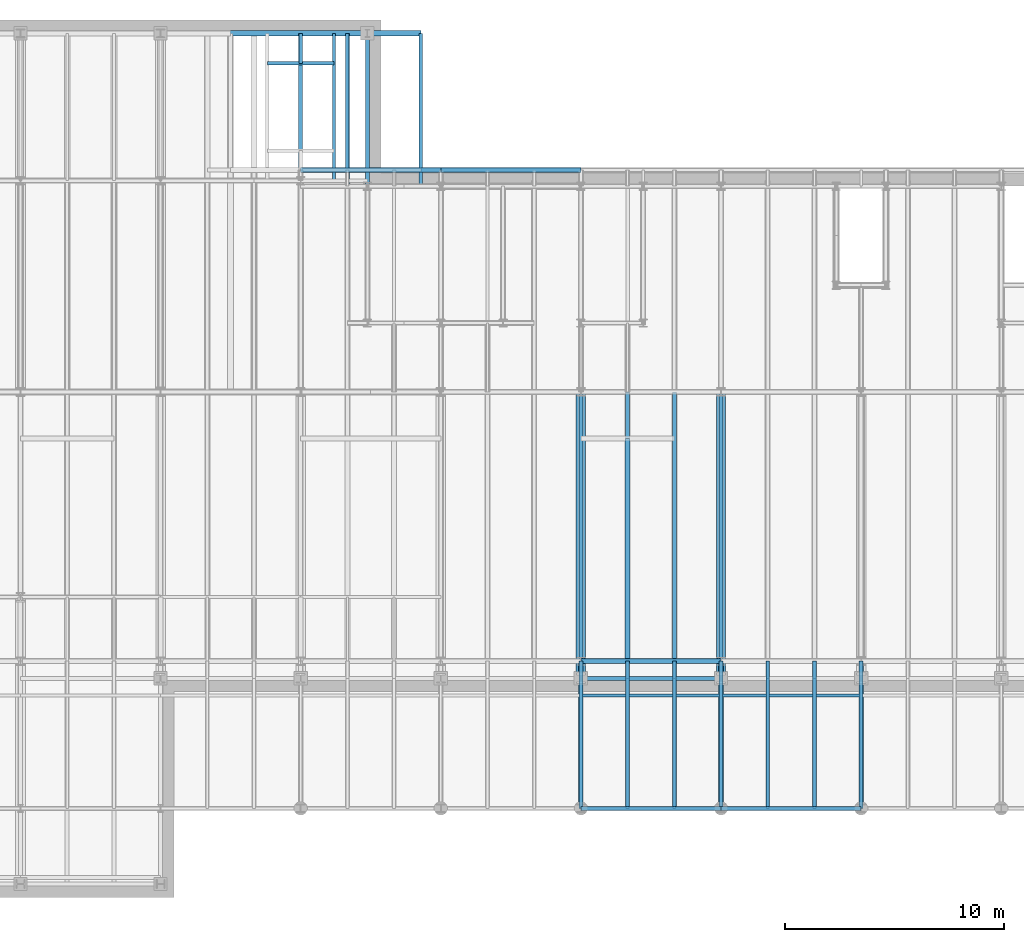
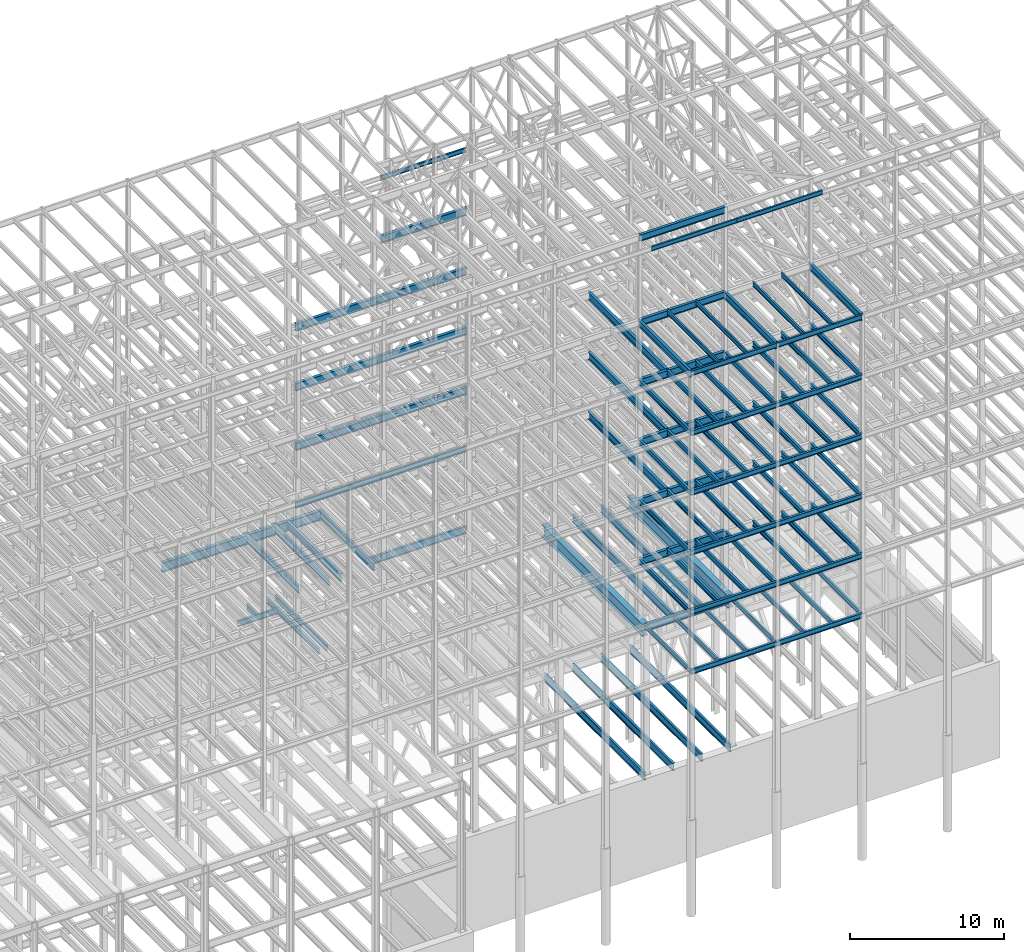
# One storey, part 138 of 150: 95 beams.
"""IFC2X3 building model written with IfcOpenShell, lengths in millimetres."""

import ifcopenshell
import ifcopenshell.guid

model = None  # the IFC model being written
_history = None  # IfcOwnerHistory: only IFC2X3 demands one
_inside = {}  # id of a spatial element -> (the spatial element, [elements in it])
_under = {}  # id of a project, library or spatial element -> (it, [spatial elements below it])
_declared = {}  # id of a project -> (the project, [libraries it declares])
_typed = {}  # id of a type object -> (the type object, [elements of that type])
_made_of = {}  # id of a material, layer set ... -> (it, [elements and type objects made of it])


def new_model(schema):
    """Start an empty IFC model of exactly this schema.

    Asked for "IFC4X3", IfcOpenShell would pick the latest addendum, in which some entities
    have other attributes; the version numbers below select the first issue.
    IFC2X3 requires an IfcOwnerHistory on every rooted entity: one is made here for all.
    """
    global model, _history
    if schema == "IFC4X3":
        model = ifcopenshell.file(schema_version=(4, 3, 0, 0))
    else:
        model = ifcopenshell.file(schema=schema)
    _inside.clear()
    _under.clear()
    _declared.clear()
    _typed.clear()
    _made_of.clear()
    _history = None
    if model.schema == "IFC2X3":
        org = make("IfcOrganization", Name="unknown")
        user = make(
            "IfcPersonAndOrganization",
            ThePerson=make("IfcPerson", FamilyName="unknown"),
            TheOrganization=org,
        )
        app = make(
            "IfcApplication",
            ApplicationDeveloper=org,
            Version="unknown",
            ApplicationFullName="unknown",
            ApplicationIdentifier="unknown",
        )
        _history = make(
            "IfcOwnerHistory",
            OwningUser=user,
            OwningApplication=app,
            ChangeAction="ADDED",
            CreationDate=0,
        )
    return model


def make(cls, **values):
    """One entity of the class cls with the attributes given. An attribute that is None is left unset."""
    return model.create_entity(
        cls, **{name: value for name, value in values.items() if value is not None}
    )


def rooted(cls, **values):
    """An entity with a GlobalId (a new one), such as an element, a storey or a relation."""
    return make(cls, GlobalId=ifcopenshell.guid.new(), OwnerHistory=_history, **values)


def si_unit(unit_type, name, prefix=None):
    """IfcSIUnit, for example si_unit("LENGTHUNIT", "METRE", prefix="MILLI")."""
    return make("IfcSIUnit", UnitType=unit_type, Prefix=prefix, Name=name)


def assignment(units):
    """IfcUnitAssignment: the units of a project."""
    return None if units is None else make("IfcUnitAssignment", Units=units)


def point(xyz):
    """IfcCartesianPoint."""
    return None if xyz is None else make("IfcCartesianPoint", Coordinates=xyz)


def direction(xyz):
    """IfcDirection."""
    return None if xyz is None else make("IfcDirection", DirectionRatios=xyz)


def frame(location, z_axis=None, x_axis=None):
    """IfcAxis2Placement3D, a coordinate frame: its origin and axes. An axis left out is left unset."""
    return make(
        "IfcAxis2Placement3D",
        Location=point(location),
        Axis=direction(z_axis),
        RefDirection=direction(x_axis),
    )


def frame_2d(location, x_axis=None):
    """IfcAxis2Placement2D, a coordinate frame in the plane: its origin and x axis."""
    return make(
        "IfcAxis2Placement2D", Location=point(location), RefDirection=direction(x_axis)
    )


def origin_with_axes():
    """The frame at (0, 0, 0) with the z axis (0, 0, 1) and the x axis (1, 0, 0) written out."""
    return frame((0.0, 0.0, 0.0), z_axis=(0.0, 0.0, 1.0), x_axis=(1.0, 0.0, 0.0))


def origin_2d_with_axis():
    """The frame at (0, 0) in the plane with the x axis (1, 0) written out."""
    return frame_2d((0.0, 0.0), x_axis=(1.0, 0.0))


def place(relative_to, where):
    """IfcLocalPlacement: puts the frame where relative to a parent placement (None: the world)."""
    return make(
        "IfcLocalPlacement", PlacementRelTo=relative_to, RelativePlacement=where
    )


def context(
    kind, dimensions, precision=None, world=None, true_north=None, identifier=None
):
    """IfcGeometricRepresentationContext, for example the 3D "Model" context."""
    return make(
        "IfcGeometricRepresentationContext",
        ContextIdentifier=identifier,
        ContextType=kind,
        CoordinateSpaceDimension=dimensions,
        Precision=precision,
        WorldCoordinateSystem=world,
        TrueNorth=true_north,
    )


def subcontext(parent, identifier, kind, view, scale=None):
    """IfcGeometricRepresentationSubContext, for example "Body" below "Model"."""
    return make(
        "IfcGeometricRepresentationSubContext",
        ContextIdentifier=identifier,
        ContextType=kind,
        ParentContext=parent,
        TargetScale=scale,
        TargetView=view,
    )


def project(units=None, contexts=None):
    """IfcProject with its units and contexts."""
    return rooted(
        "IfcProject",
        Name="project",
        RepresentationContexts=contexts,
        UnitsInContext=assignment(units),
    )


def spatial(cls, under=None, at=None, **own):
    """A site, building, storey or space (cls), placed at a placement, below another one or the project."""
    s = rooted(cls, ObjectPlacement=at, **own)
    if under is not None:
        _under.setdefault(under.id(), (under, []))[1].append(s)
    return s


def profile(cls, at=None, kind="AREA", **sizes):
    """A parametric profile (cls). Its sizes go by their IFC names, for example OverallWidth=200.0."""
    return make(cls, ProfileType=kind, Position=at, **sizes)


def i_section(**sizes):
    """IfcIShapeProfileDef."""
    return profile("IfcIShapeProfileDef", **sizes)


def extrude(swept, where, along, depth):
    """IfcExtrudedAreaSolid: the profile swept, set in the frame where, extruded along a direction by depth."""
    return make(
        "IfcExtrudedAreaSolid",
        SweptArea=swept,
        Position=where,
        ExtrudedDirection=direction(along),
        Depth=depth,
    )


def shape(context_of_items, identifier, shape_type, items):
    """IfcShapeRepresentation: the items that make up one representation, for example the "Body"."""
    return make(
        "IfcShapeRepresentation",
        ContextOfItems=context_of_items,
        RepresentationIdentifier=identifier,
        RepresentationType=shape_type,
        Items=items,
    )


def material(Name=None, Category=None):
    """IfcMaterial."""
    return make("IfcMaterial", Name=Name, Category=Category)


def made_of(thing, what):
    """Note that an element or type object is made of a material, layer set ...; save() writes the relation."""
    if what is not None:
        _made_of.setdefault(what.id(), (what, []))[1].append(thing)
    return thing


def type_object(cls, material=None, **own):
    """A type object (cls), such as IfcWallType, which elements share."""
    return made_of(rooted(cls, **own), material)


def element(
    cls,
    number,
    at=None,
    inside=None,
    cuts=None,
    type_object=None,
    material=None,
    context=None,
    identifier="Body",
    shape_type=None,
    held_by="IfcProductDefinitionShape",
    body=None,
    shapes=None,
    **own,
):
    """One element of the class cls, such as IfcWall. Its Tag is "e" and its number.

    at: its placement. inside: the storey or other place that contains it. cuts: it is an
    opening in that element (IfcRelVoidsElement). A single representation is given by context,
    identifier, shape_type and body (its items); several are given by shapes. held_by: the class
    of the entity that holds the representations. save() writes the other relations.
    """
    e = rooted(cls, Tag="e%d" % number, ObjectPlacement=at, **own)
    if body is not None:
        shapes = [shape(context, identifier, shape_type, body)]
    if shapes is not None:
        e.Representation = make(held_by, Representations=shapes)
    if inside is not None:
        _inside.setdefault(inside.id(), (inside, []))[1].append(e)
    if cuts is not None:
        rooted(
            "IfcRelVoidsElement", RelatingBuildingElement=cuts, RelatedOpeningElement=e
        )
    if type_object is not None:
        _typed.setdefault(type_object.id(), (type_object, []))[1].append(e)
    return made_of(e, material)


def aggregate(whole, parts):
    """IfcRelAggregates: a whole, such as a stair, and the parts it consists of."""
    return rooted("IfcRelAggregates", RelatingObject=whole, RelatedObjects=parts)


def save(model, path):
    """Write the relations noted so far, then the file.

    IfcRelAggregates (storeys below a building ...), IfcRelContainedInSpatialStructure (elements
    in a storey), IfcRelDefinesByType, IfcRelAssociatesMaterial and IfcRelDeclares: one each for
    every whole, place, type object, material and project.
    """
    for whole, parts in _under.values():
        aggregate(whole, parts)
    for where, things in _inside.values():
        rooted(
            "IfcRelContainedInSpatialStructure",
            RelatedElements=things,
            RelatingStructure=where,
        )
    for kind, things in _typed.values():
        rooted("IfcRelDefinesByType", RelatedObjects=things, RelatingType=kind)
    for what, things in _made_of.values():
        rooted("IfcRelAssociatesMaterial", RelatedObjects=things, RelatingMaterial=what)
    for by, libraries in _declared.values():
        rooted("IfcRelDeclares", RelatingContext=by, RelatedDefinitions=libraries)
    model.write(path)


model = new_model("IFC2X3")

# Units and contexts
model_context = context("Model", 3, precision=1e-05, world=origin_with_axes())
body_context = subcontext(model_context, "Body", "Model", "MODEL_VIEW")
ifc_project = project(units=[si_unit("LENGTHUNIT", "METRE", prefix="MILLI"), si_unit("AREAUNIT", "SQUARE_METRE"), si_unit("VOLUMEUNIT", "CUBIC_METRE"), si_unit("MASSUNIT", "GRAM", prefix="KILO"), si_unit("TIMEUNIT", "SECOND"), si_unit("PLANEANGLEUNIT", "RADIAN"), si_unit("SOLIDANGLEUNIT", "STERADIAN"), si_unit("THERMODYNAMICTEMPERATUREUNIT", "DEGREE_CELSIUS"), si_unit("LUMINOUSINTENSITYUNIT", "LUMEN")], contexts=[model_context])

# Site, building, storey
site_placement = place(None, origin_with_axes())
site = spatial("IfcSite", under=ifc_project, at=site_placement, CompositionType="ELEMENT")
building_placement = place(site_placement, origin_with_axes())
building = spatial("IfcBuilding", under=site, at=building_placement, Name="Undefined", CompositionType="ELEMENT")
storey_placement = place(building_placement, origin_with_axes())
storey = spatial("IfcBuildingStorey", under=building, at=storey_placement, Name="Undefined", CompositionType="ELEMENT", Elevation=0.0)

# Beams
ifc_material = material(Name="STEEL/A992")
beam_type_1 = type_object("IfcBeamType", Name="W18X35", PredefinedType="NOTDEFINED")
beam_1_placement = place(storey_placement, frame((56591.2, 32613.6, 35359.975), z_axis=(0.0, 0.0, 1.0), x_axis=(1.0, 0.0, 0.0)))
element("IfcBeam", 1, at=beam_1_placement, inside=storey, type_object=beam_type_1, material=ifc_material, Name="BEAM", ObjectType="W18X35", context=body_context, shape_type="SweptSolid", body=[
    extrude(i_section(OverallWidth=152.4, OverallDepth=450.85, WebThickness=7.9375, FlangeThickness=10.795, FilletRadius=17.78, at=origin_2d_with_axis()), frame((6400.80000000001, 0.0, 0.0), z_axis=(-1.0, 0.0, 0.0), x_axis=(0.0, -1.0, 0.0)), (0.0, 0.0, 1.0), 6400.80000000001),
])
beam_2_placement = place(storey_placement, frame((50190.4, 32613.6, 35359.975), z_axis=(0.0, 0.0, 1.0), x_axis=(1.0, 0.0, 0.0)))
element("IfcBeam", 2, at=beam_2_placement, inside=storey, type_object=beam_type_1, material=ifc_material, Name="BEAM", ObjectType="W18X35", context=body_context, shape_type="SweptSolid", body=[
    extrude(i_section(OverallWidth=152.4, OverallDepth=450.85, WebThickness=7.9375, FlangeThickness=10.795, FilletRadius=17.78, at=origin_2d_with_axis()), frame((6400.80000000001, 0.0, 0.0), z_axis=(-1.0, 0.0, 0.0), x_axis=(0.0, -1.0, 0.0)), (0.0, 0.0, 1.0), 6400.8),
])
beam_3_placement = place(storey_placement, frame((50190.4, 37490.4, 23548.975), z_axis=(0.0, 0.0, 1.0), x_axis=(0.0, 1.0, 0.0)))
element("IfcBeam", 3, at=beam_3_placement, inside=storey, type_object=beam_type_1, material=ifc_material, Name="BEAM", ObjectType="W18X35", context=body_context, shape_type="SweptSolid", body=[
    extrude(i_section(OverallWidth=152.4, OverallDepth=450.85, WebThickness=7.9375, FlangeThickness=10.795, FilletRadius=17.78, at=origin_2d_with_axis()), frame((1371.6, 0.0, 0.0), z_axis=(-1.0, 0.0, 0.0), x_axis=(0.0, -1.0, 0.0)), (0.0, 0.0, 1.0), 1371.6),
])
beam_4_placement = place(storey_placement, frame((48666.4, 37490.4, 23548.975), z_axis=(0.0, 0.0, 1.0), x_axis=(1.0, 0.0, 0.0)))
element("IfcBeam", 4, at=beam_4_placement, inside=storey, type_object=beam_type_1, material=ifc_material, Name="BEAM", ObjectType="W18X35", context=body_context, shape_type="SweptSolid", body=[
    extrude(i_section(OverallWidth=152.4, OverallDepth=450.85, WebThickness=7.9375, FlangeThickness=10.795, FilletRadius=17.78, at=origin_2d_with_axis()), frame((3048.0, 0.0, 0.0), z_axis=(-1.0, 0.0, 0.0), x_axis=(0.0, -1.0, 0.0)), (0.0, 0.0, 1.0), 3048.0),
])
for number, where, z_axis, x_axis, name in (
    (5, (51714.4, 32131.0, 23548.975), (0.0, 0.0, 1.0), (0.0, 1.0, 0.0), "BEAM"),
    (6, (52324.0, 32131.0, 23548.975), (0.0, 0.0, 1.0), (0.0, 1.0, 0.0), "BEAM"),
):
    element("IfcBeam", number, at=place(storey_placement, frame(where, z_axis=z_axis, x_axis=x_axis)), inside=storey, type_object=beam_type_1, material=ifc_material, Name=name, ObjectType="W18X35", context=body_context, shape_type="SweptSolid", body=[
        extrude(i_section(OverallWidth=152.4, OverallDepth=450.85, WebThickness=7.9375, FlangeThickness=10.795, FilletRadius=17.78, at=origin_2d_with_axis()), frame((6731.0, 0.0, 0.0), z_axis=(-1.0, 0.0, 0.0), x_axis=(0.0, -1.0, 0.0)), (0.0, 0.0, 1.0), 6731.0),
    ])
beam_type_2 = type_object("IfcBeamType", Name="W16X31", PredefinedType="NOTDEFINED")
beam_5_placement = place(storey_placement, frame((69392.8, 3454.4, 59005.7875), z_axis=(0.0, 0.0, 1.0), x_axis=(1.0, 0.0, 0.0)))
element("IfcBeam", 7, at=beam_5_placement, inside=storey, type_object=beam_type_2, material=ifc_material, Name="BEAM", ObjectType="W16X31", context=body_context, shape_type="SweptSolid", body=[
    extrude(i_section(OverallWidth=140.462, OverallDepth=403.225, WebThickness=6.3499, FlangeThickness=11.176, FilletRadius=17.399, at=origin_2d_with_axis()), frame((6400.80000000001, 0.0, 0.0), z_axis=(-1.0, 0.0, 0.0), x_axis=(0.0, -1.0, 0.0)), (0.0, 0.0, 1.0), 6400.80000000002),
])
beam_6_placement = place(storey_placement, frame((62992.0, 3454.4, 59005.7875), z_axis=(0.0, 0.0, 1.0), x_axis=(1.0, 0.0, 0.0)))
element("IfcBeam", 8, at=beam_6_placement, inside=storey, type_object=beam_type_2, material=ifc_material, Name="BEAM", ObjectType="W16X31", context=body_context, shape_type="SweptSolid", body=[
    extrude(i_section(OverallWidth=140.462, OverallDepth=403.225, WebThickness=6.3499, FlangeThickness=11.176, FilletRadius=17.399, at=origin_2d_with_axis()), frame((6400.80000000001, 0.0, 0.0), z_axis=(-1.0, 0.0, 0.0), x_axis=(0.0, -1.0, 0.0)), (0.0, 0.0, 1.0), 6400.8),
])
beam_type_3 = type_object("IfcBeamType", Name="W24X68", PredefinedType="NOTDEFINED")
beam_7_placement = place(storey_placement, frame((65125.6, 10185.4, 54181.375), z_axis=(0.0, 0.0, 1.0), x_axis=(0.0, 1.0, 0.0)))
element("IfcBeam", 9, at=beam_7_placement, inside=storey, type_object=beam_type_3, material=ifc_material, Name="BEAM", ObjectType="W24X68", context=body_context, shape_type="SweptSolid", body=[
    extrude(i_section(OverallWidth=227.838, OverallDepth=603.25, WebThickness=11.1125, FlangeThickness=14.859, FilletRadius=23.2409, at=origin_2d_with_axis()), frame((10159.9979680001, 0.0, 0.0), z_axis=(-1.0, 0.0, 0.0), x_axis=(0.0, -1.0, 0.0)), (0.0, 0.0, 1.0), 10159.9979680001),
])
beam_8_placement = place(storey_placement, frame((56591.2, 32613.6, 54181.375), z_axis=(0.0, 0.0, 1.0), x_axis=(1.0, 0.0, 0.0)))
element("IfcBeam", 10, at=beam_8_placement, inside=storey, type_object=beam_type_3, material=ifc_material, Name="BEAM", ObjectType="W24X68", context=body_context, shape_type="SweptSolid", body=[
    extrude(i_section(OverallWidth=227.838, OverallDepth=603.25, WebThickness=11.1125, FlangeThickness=14.859, FilletRadius=23.2409, at=origin_2d_with_axis()), frame((6400.80000000001, 0.0, 0.0), z_axis=(-1.0, 0.0, 0.0), x_axis=(0.0, -1.0, 0.0)), (0.0, 0.0, 1.0), 6400.8),
])
beam_9_placement = place(storey_placement, frame((62992.0, 10185.4, 54181.375), z_axis=(0.0, 0.0, 1.0), x_axis=(1.0, 0.0, 0.0)))
element("IfcBeam", 11, at=beam_9_placement, inside=storey, type_object=beam_type_3, material=ifc_material, Name="BEAM", ObjectType="W24X68", context=body_context, shape_type="SweptSolid", body=[
    extrude(i_section(OverallWidth=227.838, OverallDepth=603.25, WebThickness=11.1125, FlangeThickness=14.859, FilletRadius=23.2409, at=origin_2d_with_axis()), frame((6400.80000000001, 0.0, 0.0), z_axis=(-1.0, 0.0, 0.0), x_axis=(0.0, -1.0, 0.0)), (0.0, 0.0, 1.0), 6400.79999999999),
])
beam_10_placement = place(storey_placement, frame((65125.6, 10185.4, 49456.975), z_axis=(0.0, 0.0, 1.0), x_axis=(0.0, 1.0, 0.0)))
element("IfcBeam", 12, at=beam_10_placement, inside=storey, type_object=beam_type_3, material=ifc_material, Name="BEAM", ObjectType="W24X68", context=body_context, shape_type="SweptSolid", body=[
    extrude(i_section(OverallWidth=227.838, OverallDepth=603.25, WebThickness=11.1125, FlangeThickness=14.859, FilletRadius=23.2409, at=origin_2d_with_axis()), frame((10159.998984, 0.0, 0.0), z_axis=(-1.0, 0.0, 0.0), x_axis=(0.0, -1.0, 0.0)), (0.0, 0.0, 1.0), 10159.998984),
])
for number, where, z_axis, x_axis, name in (
    (13, (50190.4, 32613.6, 49456.975), (0.0, 0.0, 1.0), (1.0, 0.0, 0.0), "BEAM"),
    (14, (56591.2, 32613.6, 49456.975), (0.0, 0.0, 1.0), (1.0, 0.0, 0.0), "BEAM"),
):
    element("IfcBeam", number, at=place(storey_placement, frame(where, z_axis=z_axis, x_axis=x_axis)), inside=storey, type_object=beam_type_3, material=ifc_material, Name=name, ObjectType="W24X68", context=body_context, shape_type="SweptSolid", body=[
        extrude(i_section(OverallWidth=227.838, OverallDepth=603.25, WebThickness=11.1125, FlangeThickness=14.859, FilletRadius=23.2409, at=origin_2d_with_axis()), frame((6400.80000000001, 0.0, 0.0), z_axis=(-1.0, 0.0, 0.0), x_axis=(0.0, -1.0, 0.0)), (0.0, 0.0, 1.0), 6400.8),
    ])
beam_11_placement = place(storey_placement, frame((62992.0, 10185.4, 49456.975), z_axis=(0.0, 0.0, 1.0), x_axis=(1.0, 0.0, 0.0)))
element("IfcBeam", 15, at=beam_11_placement, inside=storey, type_object=beam_type_3, material=ifc_material, Name="BEAM", ObjectType="W24X68", context=body_context, shape_type="SweptSolid", body=[
    extrude(i_section(OverallWidth=227.838, OverallDepth=603.25, WebThickness=11.1125, FlangeThickness=14.859, FilletRadius=23.2409, at=origin_2d_with_axis()), frame((6400.80000000001, 0.0, 0.0), z_axis=(-1.0, 0.0, 0.0), x_axis=(0.0, -1.0, 0.0)), (0.0, 0.0, 1.0), 6400.79999999999),
])
beam_12_placement = place(storey_placement, frame((65125.6, 10185.4, 44732.575), z_axis=(0.0, 0.0, 1.0), x_axis=(0.0, 1.0, 0.0)))
element("IfcBeam", 16, at=beam_12_placement, inside=storey, type_object=beam_type_3, material=ifc_material, Name="BEAM", ObjectType="W24X68", context=body_context, shape_type="SweptSolid", body=[
    extrude(i_section(OverallWidth=227.838, OverallDepth=603.25, WebThickness=11.1125, FlangeThickness=14.859, FilletRadius=23.2409, at=origin_2d_with_axis()), frame((10160.0, 0.0, 0.0), z_axis=(-1.0, 0.0, 0.0), x_axis=(0.0, -1.0, 0.0)), (0.0, 0.0, 1.0), 10160.0),
])
for number, where, z_axis, x_axis, name in (
    (17, (50190.4, 32613.6, 44732.575), (0.0, 0.0, 1.0), (1.0, 0.0, 0.0), "BEAM"),
    (18, (56591.2, 32613.6, 44732.575), (0.0, 0.0, 1.0), (1.0, 0.0, 0.0), "BEAM"),
):
    element("IfcBeam", number, at=place(storey_placement, frame(where, z_axis=z_axis, x_axis=x_axis)), inside=storey, type_object=beam_type_3, material=ifc_material, Name=name, ObjectType="W24X68", context=body_context, shape_type="SweptSolid", body=[
        extrude(i_section(OverallWidth=227.838, OverallDepth=603.25, WebThickness=11.1125, FlangeThickness=14.859, FilletRadius=23.2409, at=origin_2d_with_axis()), frame((6400.80000000001, 0.0, 0.0), z_axis=(-1.0, 0.0, 0.0), x_axis=(0.0, -1.0, 0.0)), (0.0, 0.0, 1.0), 6400.8),
    ])
beam_13_placement = place(storey_placement, frame((62992.0, 10185.4, 44732.575), z_axis=(0.0, 0.0, 1.0), x_axis=(1.0, 0.0, 0.0)))
element("IfcBeam", 19, at=beam_13_placement, inside=storey, type_object=beam_type_3, material=ifc_material, Name="BEAM", ObjectType="W24X68", context=body_context, shape_type="SweptSolid", body=[
    extrude(i_section(OverallWidth=227.838, OverallDepth=603.25, WebThickness=11.1125, FlangeThickness=14.859, FilletRadius=23.2409, at=origin_2d_with_axis()), frame((6400.80000000001, 0.0, 0.0), z_axis=(-1.0, 0.0, 0.0), x_axis=(0.0, -1.0, 0.0)), (0.0, 0.0, 1.0), 6400.79999999999),
])
for number, where, z_axis, x_axis, name in (
    (20, (50190.4, 32613.6, 40008.175), (0.0, 0.0, 1.0), (1.0, 0.0, 0.0), "BEAM"),
    (21, (56591.2, 32613.6, 40008.175), (0.0, 0.0, 1.0), (1.0, 0.0, 0.0), "BEAM"),
):
    element("IfcBeam", number, at=place(storey_placement, frame(where, z_axis=z_axis, x_axis=x_axis)), inside=storey, type_object=beam_type_3, material=ifc_material, Name=name, ObjectType="W24X68", context=body_context, shape_type="SweptSolid", body=[
        extrude(i_section(OverallWidth=227.838, OverallDepth=603.25, WebThickness=11.1125, FlangeThickness=14.859, FilletRadius=23.2409, at=origin_2d_with_axis()), frame((6400.80000000001, 0.0, 0.0), z_axis=(-1.0, 0.0, 0.0), x_axis=(0.0, -1.0, 0.0)), (0.0, 0.0, 1.0), 6400.8),
    ])
beam_14_placement = place(storey_placement, frame((62992.0, 10185.4, 40008.175), z_axis=(0.0, 0.0, 1.0), x_axis=(1.0, 0.0, 0.0)))
element("IfcBeam", 22, at=beam_14_placement, inside=storey, type_object=beam_type_3, material=ifc_material, Name="BEAM", ObjectType="W24X68", context=body_context, shape_type="SweptSolid", body=[
    extrude(i_section(OverallWidth=227.838, OverallDepth=603.25, WebThickness=11.1125, FlangeThickness=14.859, FilletRadius=23.2409, at=origin_2d_with_axis()), frame((6400.80000000001, 0.0, 0.0), z_axis=(-1.0, 0.0, 0.0), x_axis=(0.0, -1.0, 0.0)), (0.0, 0.0, 1.0), 6400.79999999999),
])
beam_type_4 = type_object("IfcBeamType", Name="W14X22", PredefinedType="NOTDEFINED")
beam_15_placement = place(storey_placement, frame((69392.8, 8610.6, 65738.375), z_axis=(0.0, 0.0, 1.0), x_axis=(1.0, 0.0, 0.0)))
element("IfcBeam", 23, at=beam_15_placement, inside=storey, type_object=beam_type_4, material=ifc_material, Name="BEAM", ObjectType="W14X22", context=body_context, shape_type="SweptSolid", body=[
    extrude(i_section(OverallWidth=127.0, OverallDepth=349.25, WebThickness=6.3499, FlangeThickness=8.509, FilletRadius=18.4785, at=origin_2d_with_axis()), frame((6400.80000000001, 0.0, 0.0), z_axis=(-1.0, 0.0, 0.0), x_axis=(0.0, -1.0, 0.0)), (0.0, 0.0, 1.0), 6400.80000000002),
])
beam_16_placement = place(storey_placement, frame((62992.0, 8610.6, 65738.375), z_axis=(0.0, 0.0, 1.0), x_axis=(1.0, 0.0, 0.0)))
element("IfcBeam", 24, at=beam_16_placement, inside=storey, type_object=beam_type_4, material=ifc_material, Name="BEAM", ObjectType="W14X22", context=body_context, shape_type="SweptSolid", body=[
    extrude(i_section(OverallWidth=127.0, OverallDepth=349.25, WebThickness=6.3499, FlangeThickness=8.509, FilletRadius=18.4785, at=origin_2d_with_axis()), frame((6400.80000000001, 0.0, 0.0), z_axis=(-1.0, 0.0, 0.0), x_axis=(0.0, -1.0, 0.0)), (0.0, 0.0, 1.0), 6400.8),
])
beam_17_placement = place(storey_placement, frame((56591.2, 32613.6, 59032.775), z_axis=(0.0, 0.0, 1.0), x_axis=(1.0, 0.0, 0.0)))
element("IfcBeam", 25, at=beam_17_placement, inside=storey, type_object=beam_type_4, material=ifc_material, Name="BEAM", ObjectType="W14X22", context=body_context, shape_type="SweptSolid", body=[
    extrude(i_section(OverallWidth=127.0, OverallDepth=349.25, WebThickness=6.3499, FlangeThickness=8.509, FilletRadius=18.4785, at=origin_2d_with_axis()), frame((6400.80000000001, 0.0, 0.0), z_axis=(-1.0, 0.0, 0.0), x_axis=(0.0, -1.0, 0.0)), (0.0, 0.0, 1.0), 6400.80000000001),
])
for number, where, z_axis, x_axis, name in (
    (26, (73660.0, 3454.4, 59032.775), (0.0, 0.0, 1.0), (0.0, 1.0, 0.0), "BEAM"),
    (27, (71526.4, 3454.4, 59032.775), (0.0, 0.0, 1.0), (0.0, 1.0, 0.0), "BEAM"),
    (28, (67259.2, 3454.4, 59032.775), (0.0, 0.0, 1.0), (0.0, 1.0, 0.0), "BEAM"),
    (29, (65125.6, 3454.4, 59032.775), (0.0, 0.0, 1.0), (0.0, 1.0, 0.0), "BEAM"),
):
    element("IfcBeam", number, at=place(storey_placement, frame(where, z_axis=z_axis, x_axis=x_axis)), inside=storey, type_object=beam_type_4, material=ifc_material, Name=name, ObjectType="W14X22", context=body_context, shape_type="SweptSolid", body=[
        extrude(i_section(OverallWidth=127.0, OverallDepth=349.25, WebThickness=6.3499, FlangeThickness=8.509, FilletRadius=18.4785, at=origin_2d_with_axis()), frame((6731.0, 0.0, 0.0), z_axis=(-1.0, 0.0, 0.0), x_axis=(0.0, -1.0, 0.0)), (0.0, 0.0, 1.0), 6731.0),
    ])
for number, where, z_axis, x_axis, name in (
    (30, (75793.6, 3454.4, 35410.775), (0.0, 0.0, 1.0), (0.0, 1.0, 0.0), "BEAM"),
    (31, (73660.0, 3454.4, 35410.775), (0.0, 0.0, 1.0), (0.0, 1.0, 0.0), "BEAM"),
    (32, (71526.4, 3454.4, 35410.775), (0.0, 0.0, 1.0), (0.0, 1.0, 0.0), "BEAM"),
    (33, (69392.8, 3454.4, 35410.775), (0.0, 0.0, 1.0), (0.0, 1.0, 0.0), "BEAM"),
    (34, (67259.2, 3454.4, 35410.775), (0.0, 0.0, 1.0), (0.0, 1.0, 0.0), "BEAM"),
    (35, (65125.6, 3454.4, 35410.775), (0.0, 0.0, 1.0), (0.0, 1.0, 0.0), "BEAM"),
    (36, (62992.0, 3454.4, 35410.775), (0.0, 0.0, 1.0), (0.0, 1.0, 0.0), "BEAM"),
):
    element("IfcBeam", number, at=place(storey_placement, frame(where, z_axis=z_axis, x_axis=x_axis)), inside=storey, type_object=beam_type_4, material=ifc_material, Name=name, ObjectType="W14X22", context=body_context, shape_type="SweptSolid", body=[
        extrude(i_section(OverallWidth=127.0, OverallDepth=349.25, WebThickness=6.3499, FlangeThickness=8.509, FilletRadius=18.4785, at=origin_2d_with_axis()), frame((5943.6, 0.0, 0.0), z_axis=(-1.0, 0.0, 0.0), x_axis=(0.0, -1.0, 0.0)), (0.0, 0.0, 1.0), 5943.6),
    ])
beam_type_5 = type_object("IfcBeamType", Name="W21X55", PredefinedType="NOTDEFINED")
beam_18_placement = place(storey_placement, frame((62992.0, 10185.4, 65649.475), z_axis=(0.0, 0.0, 1.0), x_axis=(1.0, 0.0, 0.0)))
element("IfcBeam", 37, at=beam_18_placement, inside=storey, type_object=beam_type_5, material=ifc_material, Name="BEAM", ObjectType="W21X55", context=body_context, shape_type="SweptSolid", body=[
    extrude(i_section(OverallWidth=208.788, OverallDepth=527.05, WebThickness=9.5, FlangeThickness=13.2588, FilletRadius=16.8624, at=origin_2d_with_axis()), frame((6400.80000000001, 0.0, 0.0), z_axis=(-1.0, 0.0, 0.0), x_axis=(0.0, -1.0, 0.0)), (0.0, 0.0, 1.0), 6400.8),
])
for number, where, z_axis, x_axis, name in (
    (38, (75793.6, 3454.4, 58943.875), (0.0, 0.0, 1.0), (0.0, 1.0, 0.0), "BEAM"),
    (39, (69392.8, 3454.4, 58943.875), (0.0, 0.0, 1.0), (0.0, 1.0, 0.0), "BEAM"),
):
    element("IfcBeam", number, at=place(storey_placement, frame(where, z_axis=z_axis, x_axis=x_axis)), inside=storey, type_object=beam_type_5, material=ifc_material, Name=name, ObjectType="W21X55", context=body_context, shape_type="SweptSolid", body=[
        extrude(i_section(OverallWidth=208.788, OverallDepth=527.05, WebThickness=9.5, FlangeThickness=13.2588, FilletRadius=16.8624, at=origin_2d_with_axis()), frame((6731.0, 0.0, 0.0), z_axis=(-1.0, 0.0, 0.0), x_axis=(0.0, -1.0, 0.0)), (0.0, 0.0, 1.0), 6731.0),
    ])
beam_19_placement = place(storey_placement, frame((62992.0, 10185.4, 58943.875), z_axis=(0.0, 0.0, 1.0), x_axis=(1.0, 0.0, 0.0)))
element("IfcBeam", 40, at=beam_19_placement, inside=storey, type_object=beam_type_5, material=ifc_material, Name="BEAM", ObjectType="W21X55", context=body_context, shape_type="SweptSolid", body=[
    extrude(i_section(OverallWidth=208.788, OverallDepth=527.05, WebThickness=9.5, FlangeThickness=13.2588, FilletRadius=16.8624, at=origin_2d_with_axis()), frame((6400.80000000001, 0.0, 0.0), z_axis=(-1.0, 0.0, 0.0), x_axis=(0.0, -1.0, 0.0)), (0.0, 0.0, 1.0), 6400.8),
])
beam_20_placement = place(storey_placement, frame((62992.0, 3454.4, 58943.875), z_axis=(0.0, 0.0, 1.0), x_axis=(0.0, 1.0, 0.0)))
element("IfcBeam", 41, at=beam_20_placement, inside=storey, type_object=beam_type_5, material=ifc_material, Name="BEAM", ObjectType="W21X55", context=body_context, shape_type="SweptSolid", body=[
    extrude(i_section(OverallWidth=208.788, OverallDepth=527.05, WebThickness=9.5, FlangeThickness=13.2588, FilletRadius=16.8624, at=origin_2d_with_axis()), frame((6731.0, 0.0, 0.0), z_axis=(-1.0, 0.0, 0.0), x_axis=(0.0, -1.0, 0.0)), (0.0, 0.0, 1.0), 6731.0),
])
beam_type_6 = type_object("IfcBeamType", Name="W24X55", PredefinedType="NOTDEFINED")
beam_21_placement = place(storey_placement, frame((62992.0, 9398.0, 35285.3625), z_axis=(0.0, 0.0, 1.0), x_axis=(1.0, 0.0, 0.0)))
element("IfcBeam", 42, at=beam_21_placement, inside=storey, type_object=beam_type_6, material=ifc_material, Name="BEAM", ObjectType="W24X55", context=body_context, shape_type="SweptSolid", body=[
    extrude(i_section(OverallWidth=178.054, OverallDepth=600.075, WebThickness=9.5249, FlangeThickness=12.827, FilletRadius=23.6854, at=origin_2d_with_axis()), frame((6400.80000000001, 0.0, 0.0), z_axis=(-1.0, 0.0, 0.0), x_axis=(0.0, -1.0, 0.0)), (0.0, 0.0, 1.0), 6400.8),
])
beam_22_placement = place(storey_placement, frame((56591.2, 32613.6, 28986.1625), z_axis=(0.0, 0.0, 1.0), x_axis=(1.0, 0.0, 0.0)))
element("IfcBeam", 43, at=beam_22_placement, inside=storey, type_object=beam_type_6, material=ifc_material, Name="BEAM", ObjectType="W24X55", context=body_context, shape_type="SweptSolid", body=[
    extrude(i_section(OverallWidth=178.054, OverallDepth=600.075, WebThickness=9.5249, FlangeThickness=12.827, FilletRadius=23.6854, at=origin_2d_with_axis()), frame((6400.80000000001, 0.0, 0.0), z_axis=(-1.0, 0.0, 0.0), x_axis=(0.0, -1.0, 0.0)), (0.0, 0.0, 1.0), 6400.80000000001),
])
beam_23_placement = place(storey_placement, frame((55676.8, 32613.6, 28986.1625), z_axis=(0.0, 0.0, 1.0), x_axis=(1.0, 0.0, 0.0)))
element("IfcBeam", 44, at=beam_23_placement, inside=storey, type_object=beam_type_6, material=ifc_material, Name="BEAM", ObjectType="W24X55", context=body_context, shape_type="SweptSolid", body=[
    extrude(i_section(OverallWidth=178.054, OverallDepth=600.075, WebThickness=9.5249, FlangeThickness=12.827, FilletRadius=23.6854, at=origin_2d_with_axis()), frame((914.400000000009, 0.0, 0.0), z_axis=(-1.0, 0.0, 0.0), x_axis=(0.0, -1.0, 0.0)), (0.0, 0.0, 1.0), 914.400000000009),
])
beam_24_placement = place(storey_placement, frame((55676.8, 31877.0, 28986.1625), z_axis=(0.0, 0.0, 1.0), x_axis=(0.0, 1.0, 0.0)))
element("IfcBeam", 45, at=beam_24_placement, inside=storey, type_object=beam_type_6, material=ifc_material, Name="BEAM", ObjectType="W24X55", context=body_context, shape_type="SweptSolid", body=[
    extrude(i_section(OverallWidth=178.054, OverallDepth=600.075, WebThickness=9.5249, FlangeThickness=12.827, FilletRadius=23.6854, at=origin_2d_with_axis()), frame((6985.0, 0.0, 0.0), z_axis=(-1.0, 0.0, 0.0), x_axis=(0.0, -1.0, 0.0)), (0.0, 0.0, 1.0), 6984.99999999999),
])
beam_25_placement = place(storey_placement, frame((52324.0, 31877.0, 28986.1625), z_axis=(0.0, 0.0, 1.0), x_axis=(0.0, 1.0, 0.0)))
element("IfcBeam", 46, at=beam_25_placement, inside=storey, type_object=beam_type_6, material=ifc_material, Name="BEAM", ObjectType="W24X55", context=body_context, shape_type="SweptSolid", body=[
    extrude(i_section(OverallWidth=178.054, OverallDepth=600.075, WebThickness=9.5249, FlangeThickness=12.827, FilletRadius=23.6854, at=origin_2d_with_axis()), frame((6985.0, 0.0, 0.0), z_axis=(-1.0, 0.0, 0.0), x_axis=(0.0, -1.0, 0.0)), (0.0, 0.0, 1.0), 6985.0),
])
beam_26_placement = place(storey_placement, frame((53238.4, 31877.0, 28986.1625), z_axis=(0.0, 0.0, 1.0), x_axis=(0.0, 1.0, 0.0)))
element("IfcBeam", 47, at=beam_26_placement, inside=storey, type_object=beam_type_6, material=ifc_material, Name="BEAM", ObjectType="W24X55", context=body_context, shape_type="SweptSolid", body=[
    extrude(i_section(OverallWidth=178.054, OverallDepth=600.075, WebThickness=9.5249, FlangeThickness=12.827, FilletRadius=23.6854, at=origin_2d_with_axis()), frame((6985.0, 0.0, 0.0), z_axis=(-1.0, 0.0, 0.0), x_axis=(0.0, -1.0, 0.0)), (0.0, 0.0, 1.0), 6984.99999999999),
])
beam_27_placement = place(storey_placement, frame((50190.4, 32131.0, 28986.1625), z_axis=(0.0, 0.0, 1.0), x_axis=(0.0, 1.0, 0.0)))
element("IfcBeam", 48, at=beam_27_placement, inside=storey, type_object=beam_type_6, material=ifc_material, Name="BEAM", ObjectType="W24X55", context=body_context, shape_type="SweptSolid", body=[
    extrude(i_section(OverallWidth=178.054, OverallDepth=600.075, WebThickness=9.5249, FlangeThickness=12.827, FilletRadius=23.6854, at=origin_2d_with_axis()), frame((6731.0, 0.0, 0.0), z_axis=(-1.0, 0.0, 0.0), x_axis=(0.0, -1.0, 0.0)), (0.0, 0.0, 1.0), 6731.0),
])
beam_type_7 = type_object("IfcBeamType", Name="W16X36", PredefinedType="NOTDEFINED")
for number, where, z_axis, x_axis, name in (
    (49, (69392.8, 3454.4, 54281.3875), (0.0, 0.0, 1.0), (1.0, 0.0, 0.0), "BEAM"),
    (50, (62992.0, 3454.4, 54281.3875), (0.0, 0.0, 1.0), (1.0, 0.0, 0.0), "BEAM"),
):
    element("IfcBeam", number, at=place(storey_placement, frame(where, z_axis=z_axis, x_axis=x_axis)), inside=storey, type_object=beam_type_7, material=ifc_material, Name=name, ObjectType="W16X36", context=body_context, shape_type="SweptSolid", body=[
        extrude(i_section(OverallWidth=177.8, OverallDepth=403.225, WebThickness=7.9375, FlangeThickness=10.922, FilletRadius=17.6529, at=origin_2d_with_axis()), frame((6400.80000000001, 0.0, 0.0), z_axis=(-1.0, 0.0, 0.0), x_axis=(0.0, -1.0, 0.0)), (0.0, 0.0, 1.0), 6400.8),
    ])
for number, where, z_axis, x_axis, name in (
    (51, (75793.6, 3454.4, 54281.3875), (0.0, 0.0, 1.0), (0.0, 1.0, 0.0), "BEAM"),
    (52, (73660.0, 3454.4, 54281.3875), (0.0, 0.0, 1.0), (0.0, 1.0, 0.0), "BEAM"),
    (53, (71526.4, 3454.4, 54281.3875), (0.0, 0.0, 1.0), (0.0, 1.0, 0.0), "BEAM"),
    (54, (69392.8, 3454.4, 54281.3875), (0.0, 0.0, 1.0), (0.0, 1.0, 0.0), "BEAM"),
    (55, (67259.2, 3454.4, 54281.3875), (0.0, 0.0, 1.0), (0.0, 1.0, 0.0), "BEAM"),
    (56, (65125.6, 3454.4, 54281.3875), (0.0, 0.0, 1.0), (0.0, 1.0, 0.0), "BEAM"),
    (57, (62992.0, 3454.4, 54281.3875), (0.0, 0.0, 1.0), (0.0, 1.0, 0.0), "BEAM"),
):
    element("IfcBeam", number, at=place(storey_placement, frame(where, z_axis=z_axis, x_axis=x_axis)), inside=storey, type_object=beam_type_7, material=ifc_material, Name=name, ObjectType="W16X36", context=body_context, shape_type="SweptSolid", body=[
        extrude(i_section(OverallWidth=177.8, OverallDepth=403.225, WebThickness=7.9375, FlangeThickness=10.922, FilletRadius=17.6529, at=origin_2d_with_axis()), frame((6731.0, 0.0, 0.0), z_axis=(-1.0, 0.0, 0.0), x_axis=(0.0, -1.0, 0.0)), (0.0, 0.0, 1.0), 6731.0),
    ])
for number, where, z_axis, x_axis, name in (
    (58, (69392.8, 3454.4, 49556.9875), (0.0, 0.0, 1.0), (1.0, 0.0, 0.0), "BEAM"),
    (59, (62992.0, 3454.4, 49556.9875), (0.0, 0.0, 1.0), (1.0, 0.0, 0.0), "BEAM"),
):
    element("IfcBeam", number, at=place(storey_placement, frame(where, z_axis=z_axis, x_axis=x_axis)), inside=storey, type_object=beam_type_7, material=ifc_material, Name=name, ObjectType="W16X36", context=body_context, shape_type="SweptSolid", body=[
        extrude(i_section(OverallWidth=177.8, OverallDepth=403.225, WebThickness=7.9375, FlangeThickness=10.922, FilletRadius=17.6529, at=origin_2d_with_axis()), frame((6400.80000000001, 0.0, 0.0), z_axis=(-1.0, 0.0, 0.0), x_axis=(0.0, -1.0, 0.0)), (0.0, 0.0, 1.0), 6400.8),
    ])
for number, where, z_axis, x_axis, name in (
    (60, (75793.6, 3454.4, 49556.9875), (0.0, 0.0, 1.0), (0.0, 1.0, 0.0), "BEAM"),
    (61, (73660.0, 3454.4, 49556.9875), (0.0, 0.0, 1.0), (0.0, 1.0, 0.0), "BEAM"),
    (62, (71526.4, 3454.4, 49556.9875), (0.0, 0.0, 1.0), (0.0, 1.0, 0.0), "BEAM"),
    (63, (69392.8, 3454.4, 49556.9875), (0.0, 0.0, 1.0), (0.0, 1.0, 0.0), "BEAM"),
    (64, (67259.2, 3454.4, 49556.9875), (0.0, 0.0, 1.0), (0.0, 1.0, 0.0), "BEAM"),
    (65, (65125.6, 3454.4, 49556.9875), (0.0, 0.0, 1.0), (0.0, 1.0, 0.0), "BEAM"),
    (66, (62992.0, 3454.4, 49556.9875), (0.0, 0.0, 1.0), (0.0, 1.0, 0.0), "BEAM"),
):
    element("IfcBeam", number, at=place(storey_placement, frame(where, z_axis=z_axis, x_axis=x_axis)), inside=storey, type_object=beam_type_7, material=ifc_material, Name=name, ObjectType="W16X36", context=body_context, shape_type="SweptSolid", body=[
        extrude(i_section(OverallWidth=177.8, OverallDepth=403.225, WebThickness=7.9375, FlangeThickness=10.922, FilletRadius=17.6529, at=origin_2d_with_axis()), frame((6731.0, 0.0, 0.0), z_axis=(-1.0, 0.0, 0.0), x_axis=(0.0, -1.0, 0.0)), (0.0, 0.0, 1.0), 6731.0),
    ])
for number, where, z_axis, x_axis, name in (
    (67, (69392.8, 3454.4, 44832.5875), (0.0, 0.0, 1.0), (1.0, 0.0, 0.0), "BEAM"),
    (68, (62992.0, 3454.4, 44832.5875), (0.0, 0.0, 1.0), (1.0, 0.0, 0.0), "BEAM"),
):
    element("IfcBeam", number, at=place(storey_placement, frame(where, z_axis=z_axis, x_axis=x_axis)), inside=storey, type_object=beam_type_7, material=ifc_material, Name=name, ObjectType="W16X36", context=body_context, shape_type="SweptSolid", body=[
        extrude(i_section(OverallWidth=177.8, OverallDepth=403.225, WebThickness=7.9375, FlangeThickness=10.922, FilletRadius=17.6529, at=origin_2d_with_axis()), frame((6400.80000000001, 0.0, 0.0), z_axis=(-1.0, 0.0, 0.0), x_axis=(0.0, -1.0, 0.0)), (0.0, 0.0, 1.0), 6400.8),
    ])
for number, where, z_axis, x_axis, name in (
    (69, (75793.6, 3454.4, 44832.5875), (0.0, 0.0, 1.0), (0.0, 1.0, 0.0), "BEAM"),
    (70, (73660.0, 3454.4, 44832.5875), (0.0, 0.0, 1.0), (0.0, 1.0, 0.0), "BEAM"),
    (71, (71526.4, 3454.4, 44832.5875), (0.0, 0.0, 1.0), (0.0, 1.0, 0.0), "BEAM"),
    (72, (69392.8, 3454.4, 44832.5875), (0.0, 0.0, 1.0), (0.0, 1.0, 0.0), "BEAM"),
    (73, (67259.2, 3454.4, 44832.5875), (0.0, 0.0, 1.0), (0.0, 1.0, 0.0), "BEAM"),
    (74, (65125.6, 3454.4, 44832.5875), (0.0, 0.0, 1.0), (0.0, 1.0, 0.0), "BEAM"),
    (75, (62992.0, 3454.4, 44832.5875), (0.0, 0.0, 1.0), (0.0, 1.0, 0.0), "BEAM"),
):
    element("IfcBeam", number, at=place(storey_placement, frame(where, z_axis=z_axis, x_axis=x_axis)), inside=storey, type_object=beam_type_7, material=ifc_material, Name=name, ObjectType="W16X36", context=body_context, shape_type="SweptSolid", body=[
        extrude(i_section(OverallWidth=177.8, OverallDepth=403.225, WebThickness=7.9375, FlangeThickness=10.922, FilletRadius=17.6529, at=origin_2d_with_axis()), frame((6731.0, 0.0, 0.0), z_axis=(-1.0, 0.0, 0.0), x_axis=(0.0, -1.0, 0.0)), (0.0, 0.0, 1.0), 6731.0),
    ])
for number, where, z_axis, x_axis, name in (
    (76, (69392.8, 3454.4, 40108.1875), (0.0, 0.0, 1.0), (1.0, 0.0, 0.0), "BEAM"),
    (77, (62992.0, 3454.4, 40108.1875), (0.0, 0.0, 1.0), (1.0, 0.0, 0.0), "BEAM"),
):
    element("IfcBeam", number, at=place(storey_placement, frame(where, z_axis=z_axis, x_axis=x_axis)), inside=storey, type_object=beam_type_7, material=ifc_material, Name=name, ObjectType="W16X36", context=body_context, shape_type="SweptSolid", body=[
        extrude(i_section(OverallWidth=177.8, OverallDepth=403.225, WebThickness=7.9375, FlangeThickness=10.922, FilletRadius=17.6529, at=origin_2d_with_axis()), frame((6400.80000000001, 0.0, 0.0), z_axis=(-1.0, 0.0, 0.0), x_axis=(0.0, -1.0, 0.0)), (0.0, 0.0, 1.0), 6400.8),
    ])
for number, where, z_axis, x_axis, name in (
    (78, (75793.6, 3454.4, 40108.1875), (0.0, 0.0, 1.0), (0.0, 1.0, 0.0), "BEAM"),
    (79, (73660.0, 3454.4, 40108.1875), (0.0, 0.0, 1.0), (0.0, 1.0, 0.0), "BEAM"),
    (80, (71526.4, 3454.4, 40108.1875), (0.0, 0.0, 1.0), (0.0, 1.0, 0.0), "BEAM"),
    (81, (69392.8, 3454.4, 40108.1875), (0.0, 0.0, 1.0), (0.0, 1.0, 0.0), "BEAM"),
    (82, (67259.2, 3454.4, 40108.1875), (0.0, 0.0, 1.0), (0.0, 1.0, 0.0), "BEAM"),
    (83, (65125.6, 3454.4, 40108.1875), (0.0, 0.0, 1.0), (0.0, 1.0, 0.0), "BEAM"),
    (84, (62992.0, 3454.4, 40108.1875), (0.0, 0.0, 1.0), (0.0, 1.0, 0.0), "BEAM"),
):
    element("IfcBeam", number, at=place(storey_placement, frame(where, z_axis=z_axis, x_axis=x_axis)), inside=storey, type_object=beam_type_7, material=ifc_material, Name=name, ObjectType="W16X36", context=body_context, shape_type="SweptSolid", body=[
        extrude(i_section(OverallWidth=177.8, OverallDepth=403.225, WebThickness=7.9375, FlangeThickness=10.922, FilletRadius=17.6529, at=origin_2d_with_axis()), frame((6731.0, 0.0, 0.0), z_axis=(-1.0, 0.0, 0.0), x_axis=(0.0, -1.0, 0.0)), (0.0, 0.0, 1.0), 6731.0),
    ])
beam_28_placement = place(storey_placement, frame((69392.8, 3454.4, 35383.7875), z_axis=(0.0, 0.0, 1.0), x_axis=(1.0, 0.0, 0.0)))
element("IfcBeam", 85, at=beam_28_placement, inside=storey, type_object=beam_type_7, material=ifc_material, Name="BEAM", ObjectType="W16X36", context=body_context, shape_type="SweptSolid", body=[
    extrude(i_section(OverallWidth=177.8, OverallDepth=403.225, WebThickness=7.9375, FlangeThickness=10.922, FilletRadius=17.6529, at=origin_2d_with_axis()), frame((6400.80000000001, 0.0, 0.0), z_axis=(-1.0, 0.0, 0.0), x_axis=(0.0, -1.0, 0.0)), (0.0, 0.0, 1.0), 6400.8),
])
beam_29_placement = place(storey_placement, frame((62992.0, 3454.4, 35383.7875), z_axis=(0.0, 0.0, 1.0), x_axis=(1.0, 0.0, 0.0)))
element("IfcBeam", 86, at=beam_29_placement, inside=storey, type_object=beam_type_7, material=ifc_material, Name="BEAM", ObjectType="W16X36", context=body_context, shape_type="SweptSolid", body=[
    extrude(i_section(OverallWidth=177.8, OverallDepth=403.225, WebThickness=7.9375, FlangeThickness=10.922, FilletRadius=17.6529, at=origin_2d_with_axis()), frame((6400.80000000001, 0.0, 0.0), z_axis=(-1.0, 0.0, 0.0), x_axis=(0.0, -1.0, 0.0)), (0.0, 0.0, 1.0), 6400.79999999999),
])
beam_type_8 = type_object("IfcBeamType", Name="W24X62", PredefinedType="NOTDEFINED")
for number, where, z_axis, x_axis, name in (
    (87, (67259.19935992, 9398.0, 35283.775), (0.0, 0.0, 1.0), (0.0, 1.0, 0.0), "BEAM"),
    (88, (65125.59935992, 9398.0, 35283.775), (0.0, 0.0, 1.0), (0.0, 1.0, 0.0), "BEAM"),
    (89, (69392.8, 9398.0, 23472.775), (0.0, 0.0, 1.0), (0.0, 1.0, 0.0), "BEAM"),
    (90, (67259.2, 9398.0, 23472.775), (0.0, 0.0, 1.0), (0.0, 1.0, 0.0), "BEAM"),
    (91, (65125.6, 9398.0, 23472.775), (0.0, 0.0, 1.0), (0.0, 1.0, 0.0), "BEAM"),
    (92, (62992.0, 9398.0, 23472.775), (0.0, 0.0, 1.0), (0.0, 1.0, 0.0), "BEAM"),
):
    element("IfcBeam", number, at=place(storey_placement, frame(where, z_axis=z_axis, x_axis=x_axis)), inside=storey, type_object=beam_type_8, material=ifc_material, Name=name, ObjectType="W24X62", context=body_context, shape_type="SweptSolid", body=[
        extrude(i_section(OverallWidth=177.8, OverallDepth=603.25, WebThickness=11.1125, FlangeThickness=14.986, FilletRadius=23.114, at=origin_2d_with_axis()), frame((13081.0, 0.0, 0.0), z_axis=(-1.0, 0.0, 0.0), x_axis=(0.0, -1.0, 0.0)), (0.0, 0.0, 1.0), 13081.0),
    ])
beam_type_9 = type_object("IfcBeamType", Name="W30X90", PredefinedType="NOTDEFINED")
beam_30_placement = place(storey_placement, frame((43789.6, 38862.0, 28911.55), z_axis=(0.0, 0.0, 1.0), x_axis=(1.0, 0.0, 0.0)))
element("IfcBeam", 93, at=beam_30_placement, inside=storey, type_object=beam_type_9, material=ifc_material, Name="BEAM", ObjectType="W30X90", context=body_context, shape_type="SweptSolid", body=[
    extrude(i_section(OverallWidth=264.16, OverallDepth=749.3, WebThickness=12.6999, FlangeThickness=15.494, FilletRadius=22.606, at=origin_2d_with_axis()), frame((11887.2, 0.0, 0.0), z_axis=(-1.0, 0.0, 0.0), x_axis=(0.0, -1.0, 0.0)), (0.0, 0.0, 1.0), 11887.2),
])
beam_type_10 = type_object("IfcBeamType", Name="W36X395", PredefinedType="NOTDEFINED")
for number, where, z_axis, x_axis, name in (
    (94, (69392.8, 9398.0, 35098.0375), (0.0, 0.0, 1.0), (0.0, 1.0, 0.0), "BEAM"),
    (95, (62992.0, 9398.0, 35098.0375), (0.0, 0.0, 1.0), (0.0, 1.0, 0.0), "BEAM"),
):
    element("IfcBeam", number, at=place(storey_placement, frame(where, z_axis=z_axis, x_axis=x_axis)), inside=storey, type_object=beam_type_10, material=ifc_material, Name=name, ObjectType="W36X395", context=body_context, shape_type="SweptSolid", body=[
        extrude(i_section(OverallWidth=428.625, OverallDepth=974.725, WebThickness=30.988, FlangeThickness=55.88, FilletRadius=31.4324, at=origin_2d_with_axis()), frame((13081.0, 0.0, 0.0), z_axis=(-1.0, 0.0, 0.0), x_axis=(0.0, -1.0, 0.0)), (0.0, 0.0, 1.0), 13081.0),
    ])

save(model, "model.ifc")
